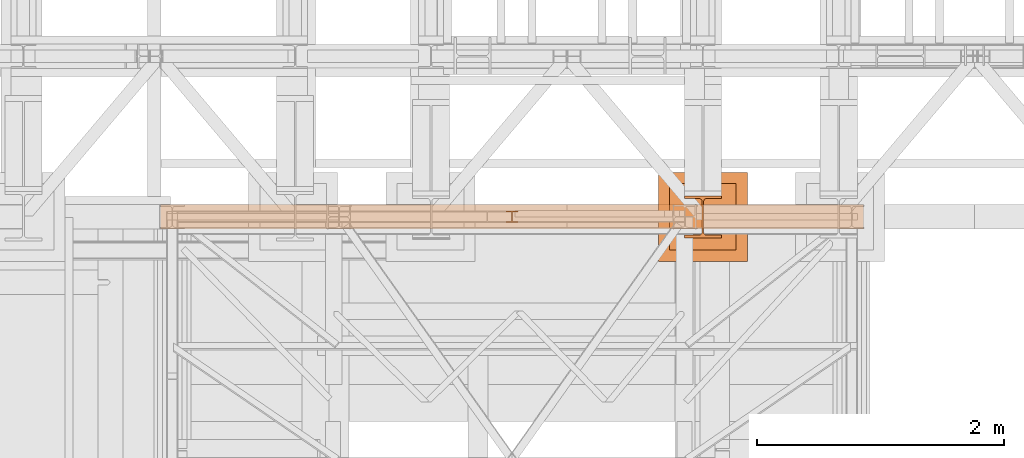
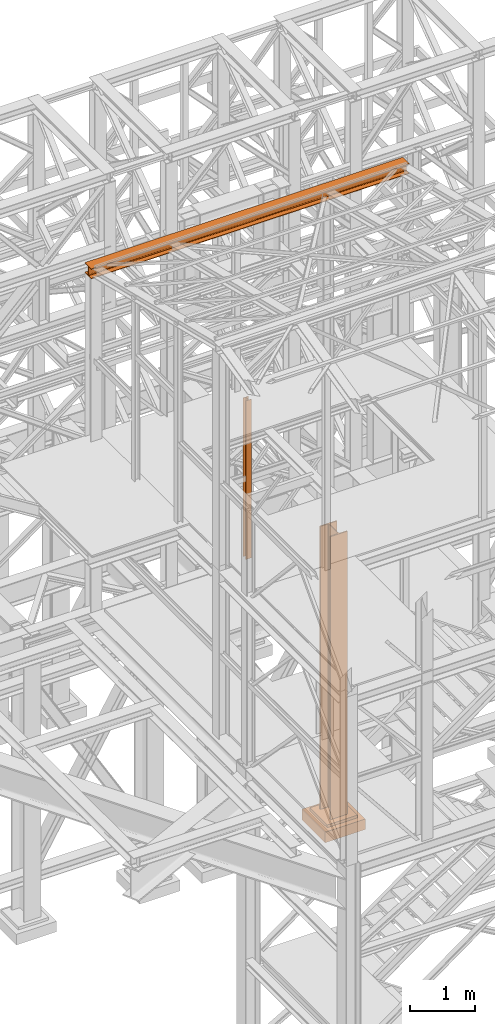
# One storey, part 74 of 208: 4 proxies.
"""IFC2X3 building model written with IfcOpenShell, lengths in millimetres."""

import ifcopenshell
import ifcopenshell.guid

model = None  # the IFC model being written
_history = None  # IfcOwnerHistory: only IFC2X3 demands one
_inside = {}  # id of a spatial element -> (the spatial element, [elements in it])
_under = {}  # id of a project, library or spatial element -> (it, [spatial elements below it])
_declared = {}  # id of a project -> (the project, [libraries it declares])
_typed = {}  # id of a type object -> (the type object, [elements of that type])
_made_of = {}  # id of a material, layer set ... -> (it, [elements and type objects made of it])


def new_model(schema):
    """Start an empty IFC model of exactly this schema.

    Asked for "IFC4X3", IfcOpenShell would pick the latest addendum, in which some entities
    have other attributes; the version numbers below select the first issue.
    IFC2X3 requires an IfcOwnerHistory on every rooted entity: one is made here for all.
    """
    global model, _history
    if schema == "IFC4X3":
        model = ifcopenshell.file(schema_version=(4, 3, 0, 0))
    else:
        model = ifcopenshell.file(schema=schema)
    _inside.clear()
    _under.clear()
    _declared.clear()
    _typed.clear()
    _made_of.clear()
    _history = None
    if model.schema == "IFC2X3":
        org = make("IfcOrganization", Name="unknown")
        user = make(
            "IfcPersonAndOrganization",
            ThePerson=make("IfcPerson", FamilyName="unknown"),
            TheOrganization=org,
        )
        app = make(
            "IfcApplication",
            ApplicationDeveloper=org,
            Version="unknown",
            ApplicationFullName="unknown",
            ApplicationIdentifier="unknown",
        )
        _history = make(
            "IfcOwnerHistory",
            OwningUser=user,
            OwningApplication=app,
            ChangeAction="ADDED",
            CreationDate=0,
        )
    return model


def make(cls, **values):
    """One entity of the class cls with the attributes given. An attribute that is None is left unset."""
    return model.create_entity(
        cls, **{name: value for name, value in values.items() if value is not None}
    )


def entity(cls, *values):
    """Any entity or typed value of the class cls, its attributes in the order of the schema. None: left unset."""
    e = model.create_entity(cls)
    for i, value in enumerate(values):
        if value is not None:
            e[i] = value
    return e


def rooted(cls, **values):
    """An entity with a GlobalId (a new one), such as an element, a storey or a relation."""
    return make(cls, GlobalId=ifcopenshell.guid.new(), OwnerHistory=_history, **values)


def si_unit(unit_type, name, prefix=None):
    """IfcSIUnit, for example si_unit("LENGTHUNIT", "METRE", prefix="MILLI")."""
    return make("IfcSIUnit", UnitType=unit_type, Prefix=prefix, Name=name)


def converted_unit(unit_type, name, factor, base, dimensions=None, offset=None):
    """IfcConversionBasedUnit, such as the inch: factor (a typed value) times the base unit."""
    return make(
        "IfcConversionBasedUnit"
        if offset is None
        else "IfcConversionBasedUnitWithOffset",
        ConversionOffset=offset,
        Dimensions=None
        if dimensions is None
        else entity("IfcDimensionalExponents", *dimensions),
        UnitType=unit_type,
        Name=name,
        ConversionFactor=make(
            "IfcMeasureWithUnit", ValueComponent=factor, UnitComponent=base
        ),
    )


def assignment(units):
    """IfcUnitAssignment: the units of a project."""
    return None if units is None else make("IfcUnitAssignment", Units=units)


def point(xyz):
    """IfcCartesianPoint."""
    return None if xyz is None else make("IfcCartesianPoint", Coordinates=xyz)


def direction(xyz):
    """IfcDirection."""
    return None if xyz is None else make("IfcDirection", DirectionRatios=xyz)


def frame(location, z_axis=None, x_axis=None):
    """IfcAxis2Placement3D, a coordinate frame: its origin and axes. An axis left out is left unset."""
    return make(
        "IfcAxis2Placement3D",
        Location=point(location),
        Axis=direction(z_axis),
        RefDirection=direction(x_axis),
    )


def origin():
    """The frame at (0, 0, 0) with its axes left unset."""
    return frame((0.0, 0.0, 0.0))


def origin_with_axes():
    """The frame at (0, 0, 0) with the z axis (0, 0, 1) and the x axis (1, 0, 0) written out."""
    return frame((0.0, 0.0, 0.0), z_axis=(0.0, 0.0, 1.0), x_axis=(1.0, 0.0, 0.0))


def place(relative_to, where):
    """IfcLocalPlacement: puts the frame where relative to a parent placement (None: the world)."""
    return make(
        "IfcLocalPlacement", PlacementRelTo=relative_to, RelativePlacement=where
    )


def context(
    kind, dimensions, precision=None, world=None, true_north=None, identifier=None
):
    """IfcGeometricRepresentationContext, for example the 3D "Model" context."""
    return make(
        "IfcGeometricRepresentationContext",
        ContextIdentifier=identifier,
        ContextType=kind,
        CoordinateSpaceDimension=dimensions,
        Precision=precision,
        WorldCoordinateSystem=world,
        TrueNorth=true_north,
    )


def subcontext(parent, identifier, kind, view, scale=None):
    """IfcGeometricRepresentationSubContext, for example "Body" below "Model"."""
    return make(
        "IfcGeometricRepresentationSubContext",
        ContextIdentifier=identifier,
        ContextType=kind,
        ParentContext=parent,
        TargetScale=scale,
        TargetView=view,
    )


def project(units=None, contexts=None):
    """IfcProject with its units and contexts."""
    return rooted(
        "IfcProject",
        Name="project",
        RepresentationContexts=contexts,
        UnitsInContext=assignment(units),
    )


def spatial(cls, under=None, at=None, **own):
    """A site, building, storey or space (cls), placed at a placement, below another one or the project."""
    s = rooted(cls, ObjectPlacement=at, **own)
    if under is not None:
        _under.setdefault(under.id(), (under, []))[1].append(s)
    return s


def faces_of(points, faces, orient=None, outer=None):
    """IfcFace entities. A face is a list of loops; a loop is a list of indices into points, from 0.

    orient and outer hold one flag for each loop. By default every Orientation is true, the
    first loop of a face is its IfcFaceOuterBound and the others are IfcFaceBound.
    """
    made = []
    for i, loops in enumerate(faces):
        bounds = []
        for j, loop in enumerate(loops):
            is_outer = j == 0 if outer is None else outer[i][j]
            bounds.append(
                make(
                    "IfcFaceOuterBound" if is_outer else "IfcFaceBound",
                    Bound=make("IfcPolyLoop", Polygon=[points[k] for k in loop]),
                    Orientation=True if orient is None else orient[i][j],
                )
            )
        made.append(make("IfcFace", Bounds=bounds))
    return made


def faceted_brep(points, faces, orient=None, outer=None, voids=None):
    """IfcFacetedBrep: a solid bounded by flat faces; with voids (closed shells), ...WithVoids."""
    shared = [point(p) for p in points]
    hull = make("IfcClosedShell", CfsFaces=faces_of(shared, faces, orient, outer))
    if voids is None:
        return make("IfcFacetedBrep", Outer=hull)
    return make(
        "IfcFacetedBrepWithVoids",
        Outer=hull,
        Voids=[
            make(cls, CfsFaces=faces_of(shared, fs, o, b)) for cls, fs, o, b in voids
        ],
    )


def shape(context_of_items, identifier, shape_type, items):
    """IfcShapeRepresentation: the items that make up one representation, for example the "Body"."""
    return make(
        "IfcShapeRepresentation",
        ContextOfItems=context_of_items,
        RepresentationIdentifier=identifier,
        RepresentationType=shape_type,
        Items=items,
    )


def material(Name=None, Category=None):
    """IfcMaterial."""
    return make("IfcMaterial", Name=Name, Category=Category)


def made_of(thing, what):
    """Note that an element or type object is made of a material, layer set ...; save() writes the relation."""
    if what is not None:
        _made_of.setdefault(what.id(), (what, []))[1].append(thing)
    return thing


def element(
    cls,
    number,
    at=None,
    inside=None,
    cuts=None,
    type_object=None,
    material=None,
    context=None,
    identifier="Body",
    shape_type=None,
    held_by="IfcProductDefinitionShape",
    body=None,
    shapes=None,
    **own,
):
    """One element of the class cls, such as IfcWall. Its Tag is "e" and its number.

    at: its placement. inside: the storey or other place that contains it. cuts: it is an
    opening in that element (IfcRelVoidsElement). A single representation is given by context,
    identifier, shape_type and body (its items); several are given by shapes. held_by: the class
    of the entity that holds the representations. save() writes the other relations.
    """
    e = rooted(cls, Tag="e%d" % number, ObjectPlacement=at, **own)
    if body is not None:
        shapes = [shape(context, identifier, shape_type, body)]
    if shapes is not None:
        e.Representation = make(held_by, Representations=shapes)
    if inside is not None:
        _inside.setdefault(inside.id(), (inside, []))[1].append(e)
    if cuts is not None:
        rooted(
            "IfcRelVoidsElement", RelatingBuildingElement=cuts, RelatedOpeningElement=e
        )
    if type_object is not None:
        _typed.setdefault(type_object.id(), (type_object, []))[1].append(e)
    return made_of(e, material)


def aggregate(whole, parts):
    """IfcRelAggregates: a whole, such as a stair, and the parts it consists of."""
    return rooted("IfcRelAggregates", RelatingObject=whole, RelatedObjects=parts)


def save(model, path):
    """Write the relations noted so far, then the file.

    IfcRelAggregates (storeys below a building ...), IfcRelContainedInSpatialStructure (elements
    in a storey), IfcRelDefinesByType, IfcRelAssociatesMaterial and IfcRelDeclares: one each for
    every whole, place, type object, material and project.
    """
    for whole, parts in _under.values():
        aggregate(whole, parts)
    for where, things in _inside.values():
        rooted(
            "IfcRelContainedInSpatialStructure",
            RelatedElements=things,
            RelatingStructure=where,
        )
    for kind, things in _typed.values():
        rooted("IfcRelDefinesByType", RelatedObjects=things, RelatingType=kind)
    for what, things in _made_of.values():
        rooted("IfcRelAssociatesMaterial", RelatedObjects=things, RelatingMaterial=what)
    for by, libraries in _declared.values():
        rooted("IfcRelDeclares", RelatingContext=by, RelatedDefinitions=libraries)
    model.write(path)


model = new_model("IFC2X3")

# Units and contexts
model_context = context("Model", 3, precision=1e-05, world=origin())
plan_context = context("Plan", 3, precision=1e-05, world=origin())
body_context = subcontext(model_context, "Body", "Model", "MODEL_VIEW")
ifc_project = project(units=[si_unit("LENGTHUNIT", "METRE", prefix="MILLI"), converted_unit("PLANEANGLEUNIT", "DEGREE", entity("IfcPlaneAngleMeasure", 0.0174532925199433), si_unit("PLANEANGLEUNIT", "RADIAN"), dimensions=[0, 0, 0, 0, 0, 0, 0]), si_unit("AREAUNIT", "SQUARE_METRE"), si_unit("VOLUMEUNIT", "CUBIC_METRE")], contexts=[model_context, plan_context])

# Building, storey
building_placement = place(None, origin())
building = spatial("IfcBuilding", under=ifc_project, at=building_placement, CompositionType="COMPLEX")
storey_placement = place(building_placement, origin_with_axes())
storey = spatial("IfcBuildingStorey", under=building, at=storey_placement, Name="Geschoss", CompositionType="ELEMENT")

# Proxies
proxy_1_placement = place(storey_placement, frame((1103.254962270171, -17362.57439031789, 11599.98999433756), z_axis=(0.0, 0.0, 1.0), x_axis=(1.0, 0.0, 0.0)))
element("IfcBuildingElementProxy", 1, at=proxy_1_placement, inside=storey, context=body_context, shape_type="Brep", body=[
    faceted_brep([(0.01000000000021828, 0.00999999999839929, 190.0100000000002), (5690.010012516976, 0.00999999999839929, 190.0100000000002), (5690.010012516976, 0.00999999999839929, 180.0100000000002), (0.01000000000021828, 0.00999999999839929, 180.0100000000002), (0.01000000000021828, 0.00999999999839929, 180.0100000000002), (5690.010012516976, 0.00999999999839929, 180.0100000000002), (5690.010012516976, 78.7599999999984, 180.0100000000002), (0.01000000000021828, 78.7599999999984, 180.0100000000002), (0.01000000000021828, 78.7599999999984, 180.0100000000002), (5690.010012516976, 78.7599999999984, 180.0100000000002), (5690.010012516976, 84.32228703057262, 179.128955961507), (0.01000000000021828, 84.32228703057262, 179.128955961507), (0.01000000000021828, 84.32228703057262, 179.128955961507), (5690.010012516976, 84.32228703057262, 179.128955961507), (5690.010012516976, 89.34011671053304, 176.5722836422683), (0.01000000000021828, 89.34011671053668, 176.5722836422683), (0.01000000000021828, 89.34011671053668, 176.5722836422683), (5690.010012516976, 89.34011671053304, 176.5722836422683), (5690.010012516976, 93.32228364226467, 172.5901167105349), (0.01000000000021828, 93.32228364226467, 172.5901167105349), (0.01000000000021828, 93.32228364226467, 172.5901167105349), (5690.010012516976, 93.32228364226467, 172.5901167105349), (5690.010012516976, 95.87895596150338, 167.5722870305744), (0.01000000000021828, 95.87895596150338, 167.5722870305744), (0.01000000000021828, 95.87895596150338, 167.5722870305744), (5690.010012516976, 95.87895596150338, 167.5722870305744), (5690.010012516976, 96.7599999999984, 162.0100000000002), (0.01000000000021828, 96.7599999999984, 162.0100000000002), (0.01000000000021828, 96.7599999999984, 162.0100000000002), (5690.010012516976, 96.7599999999984, 162.0100000000002), (5690.010012516976, 96.7599999999984, 28.01000000000022), (0.01000000000021828, 96.7599999999984, 28.01000000000022), (0.01000000000021828, 96.7599999999984, 28.01000000000022), (5690.010012516976, 96.7599999999984, 28.01000000000022), (5690.010012516976, 95.87895596150338, 22.44771296942599), (0.01000000000021828, 95.87895596150338, 22.44771296942599), (0.01000000000021828, 95.87895596150338, 22.44771296942599), (5690.010012516976, 95.87895596150338, 22.44771296942599), (5690.010012516976, 93.32228364226467, 17.42988328946558), (0.01000000000021828, 93.32228364226467, 17.42988328946558), (0.01000000000021828, 93.32228364226467, 17.42988328946558), (5690.010012516976, 93.32228364226467, 17.42988328946558), (5690.010012516976, 89.34011671053304, 13.44771635773213), (0.01000000000021828, 89.34011671053668, 13.44771635773395), (0.01000000000021828, 89.34011671053668, 13.44771635773395), (5690.010012516976, 89.34011671053304, 13.44771635773213), (5690.010012516976, 84.32228703057262, 10.89104403849342), (0.01000000000021828, 84.32228703057262, 10.89104403849342), (0.01000000000021828, 84.32228703057262, 10.89104403849342), (5690.010012516976, 84.32228703057262, 10.89104403849342), (5690.010012516976, 80.0099999999984, 10.01000000000022), (0.01000000000021828, 80.0099999999984, 10.01000000000022), (0.01000000000021828, 80.0099999999984, 10.01000000000022), (5690.010012516976, 80.0099999999984, 10.01000000000022), (5690.010012516976, 0.00999999999839929, 10.01000000000022), (0.01000000000021828, 0.00999999999839929, 10.01000000000022), (0.01000000000021828, 0.00999999999839929, 10.01000000000022), (5690.010012516976, 0.00999999999839929, 10.01000000000022), (5690.010012516976, 0.00999999999839929, 0.01000000000021828), (0.01000000000021828, 0.00999999999839929, 0.01000000000021828), (0.01000000000021828, 0.00999999999839929, 0.01000000000021828), (5690.010012516976, 0.00999999999839929, 0.01000000000021828), (5690.010012516976, 200.0099999999984, 0.01000000000021828), (0.01000000000021828, 200.0099999999984, 0.01000000000021828), (0.01000000000021828, 200.0099999999984, 0.01000000000021828), (5690.010012516976, 200.0099999999984, 0.01000000000021828), (5690.010012516976, 200.0099999999984, 10.01000000000022), (0.01000000000021828, 200.0099999999984, 10.01000000000022), (0.01000000000021828, 200.0099999999984, 10.01000000000022), (5690.010012516976, 200.0099999999984, 10.01000000000022), (5690.010012516976, 121.2599999999984, 10.01000000000022), (0.01000000000021828, 121.2599999999984, 10.01000000000022), (0.01000000000021828, 121.2599999999984, 10.01000000000022), (5690.010012516976, 121.2599999999984, 10.01000000000022), (5690.010012516976, 115.6977129694242, 10.89104403849342), (0.01000000000021828, 115.6977129694242, 10.89104403849342), (0.01000000000021828, 115.6977129694242, 10.89104403849342), (5690.010012516976, 115.6977129694242, 10.89104403849342), (5690.010012516976, 110.6798832894638, 13.44771635773213), (0.01000000000021828, 110.6798832894638, 13.44771635773213), (0.01000000000021828, 110.6798832894638, 13.44771635773213), (5690.010012516976, 110.6798832894638, 13.44771635773213), (5690.010012516976, 106.6977163577285, 17.42988328946558), (0.01000000000021828, 106.6977163577285, 17.42988328946558), (0.01000000000021828, 106.6977163577285, 17.42988328946558), (5690.010012516976, 106.6977163577285, 17.42988328946558), (5690.010012516976, 104.1410440384934, 22.44771296942599), (0.01000000000021828, 104.1410440384934, 22.44771296942599), (0.01000000000021828, 104.1410440384934, 22.44771296942599), (5690.010012516976, 104.1410440384934, 22.44771296942599), (5690.010012516976, 103.2599999999984, 28.01000000000022), (0.01000000000021828, 103.2599999999984, 28.01000000000022), (0.01000000000021828, 103.2599999999984, 28.01000000000022), (5690.010012516976, 103.2599999999984, 28.01000000000022), (5690.010012516976, 103.2599999999984, 162.0100000000002), (0.01000000000021828, 103.2599999999984, 162.0100000000002), (0.01000000000021828, 103.2599999999984, 162.0100000000002), (5690.010012516976, 103.2599999999984, 162.0100000000002), (5690.010012516976, 104.1410440384934, 167.5722870305744), (0.01000000000021828, 104.1410440384934, 167.5722870305744), (0.01000000000021828, 104.1410440384934, 167.5722870305744), (5690.010012516976, 104.1410440384934, 167.5722870305744), (5690.010012516976, 106.6977163577285, 172.5901167105349), (0.01000000000021828, 106.6977163577285, 172.5901167105349), (0.01000000000021828, 106.6977163577285, 172.5901167105349), (5690.010012516976, 106.6977163577285, 172.5901167105349), (5690.010012516976, 110.6798832894638, 176.5722836422683), (0.01000000000021828, 110.6798832894638, 176.5722836422683), (0.01000000000021828, 110.6798832894638, 176.5722836422683), (5690.010012516976, 110.6798832894638, 176.5722836422683), (5690.010012516976, 115.6977129694242, 179.128955961507), (0.01000000000021828, 115.6977129694242, 179.128955961507), (0.01000000000021828, 115.6977129694242, 179.128955961507), (5690.010012516976, 115.6977129694242, 179.128955961507), (5690.010012516976, 121.2599999999984, 180.0100000000002), (0.01000000000021828, 121.2599999999984, 180.0100000000002), (0.01000000000021828, 121.2599999999984, 180.0100000000002), (5690.010012516976, 121.2599999999984, 180.0100000000002), (5690.010012516976, 200.0099999999984, 180.0100000000002), (0.01000000000021828, 200.0099999999984, 180.0100000000002), (0.01000000000021828, 200.0099999999984, 180.0100000000002), (5690.010012516976, 200.0099999999984, 180.0100000000002), (5690.010012516976, 200.0099999999984, 190.0100000000002), (0.01000000000021828, 200.0099999999984, 190.0100000000002), (0.01000000000021828, 200.0099999999984, 190.0100000000002), (5690.010012516976, 200.0099999999984, 190.0100000000002), (5690.010012516976, 0.00999999999839929, 190.0100000000002), (0.01000000000021828, 0.00999999999839929, 190.0100000000002), (5690.010012516976, 0.00999999999839929, 190.0100000000002), (5690.010012516976, 200.0099999999984, 190.0100000000002), (5690.010012516976, 200.0099999999984, 180.0100000000002), (5690.010012516976, 121.2599999999984, 180.0100000000002), (5690.010012516976, 115.6977129694242, 179.128955961507), (5690.010012516976, 110.6798832894638, 176.5722836422683), (5690.010012516976, 106.6977163577285, 172.5901167105349), (5690.010012516976, 104.1410440384934, 167.5722870305744), (5690.010012516976, 103.2599999999984, 162.0100000000002), (5690.010012516976, 103.2599999999984, 28.01000000000022), (5690.010012516976, 104.1410440384934, 22.44771296942599), (5690.010012516976, 106.6977163577285, 17.42988328946558), (5690.010012516976, 110.6798832894638, 13.44771635773213), (5690.010012516976, 115.6977129694242, 10.89104403849342), (5690.010012516976, 121.2599999999984, 10.01000000000022), (5690.010012516976, 200.0099999999984, 10.01000000000022), (5690.010012516976, 200.0099999999984, 0.01000000000021828), (5690.010012516976, 0.00999999999839929, 0.01000000000021828), (5690.010012516976, 0.00999999999839929, 10.01000000000022), (5690.010012516976, 80.0099999999984, 10.01000000000022), (5690.010012516976, 84.32228703057262, 10.89104403849342), (5690.010012516976, 89.34011671053304, 13.44771635773213), (5690.010012516976, 93.32228364226467, 17.42988328946558), (5690.010012516976, 95.87895596150338, 22.44771296942599), (5690.010012516976, 96.7599999999984, 28.01000000000022), (5690.010012516976, 96.7599999999984, 162.0100000000002), (5690.010012516976, 95.87895596150338, 167.5722870305744), (5690.010012516976, 93.32228364226467, 172.5901167105349), (5690.010012516976, 89.34011671053304, 176.5722836422683), (5690.010012516976, 84.32228703057262, 179.128955961507), (5690.010012516976, 78.7599999999984, 180.0100000000002), (5690.010012516976, 0.00999999999839929, 180.0100000000002), (0.01000000000021828, 0.00999999999839929, 180.0100000000002), (0.01000000000021828, 78.7599999999984, 180.0100000000002), (0.01000000000021828, 84.32228703057262, 179.128955961507), (0.01000000000021828, 89.34011671053668, 176.5722836422683), (0.01000000000021828, 93.32228364226467, 172.5901167105349), (0.01000000000021828, 95.87895596150338, 167.5722870305744), (0.01000000000021828, 96.7599999999984, 162.0100000000002), (0.01000000000021828, 96.7599999999984, 28.01000000000022), (0.01000000000021828, 95.87895596150338, 22.44771296942599), (0.01000000000021828, 93.32228364226467, 17.42988328946558), (0.01000000000021828, 89.34011671053668, 13.44771635773395), (0.01000000000021828, 84.32228703057262, 10.89104403849342), (0.01000000000021828, 80.0099999999984, 10.01000000000022), (0.01000000000021828, 0.00999999999839929, 10.01000000000022), (0.01000000000021828, 0.00999999999839929, 0.01000000000021828), (0.01000000000021828, 200.0099999999984, 0.01000000000021828), (0.01000000000021828, 200.0099999999984, 10.01000000000022), (0.01000000000021828, 121.2599999999984, 10.01000000000022), (0.01000000000021828, 115.6977129694242, 10.89104403849342), (0.01000000000021828, 110.6798832894638, 13.44771635773213), (0.01000000000021828, 106.6977163577285, 17.42988328946558), (0.01000000000021828, 104.1410440384934, 22.44771296942599), (0.01000000000021828, 103.2599999999984, 28.01000000000022), (0.01000000000021828, 103.2599999999984, 162.0100000000002), (0.01000000000021828, 104.1410440384934, 167.5722870305744), (0.01000000000021828, 106.6977163577285, 172.5901167105349), (0.01000000000021828, 110.6798832894638, 176.5722836422683), (0.01000000000021828, 115.6977129694242, 179.128955961507), (0.01000000000021828, 121.2599999999984, 180.0100000000002), (0.01000000000021828, 200.0099999999984, 180.0100000000002), (0.01000000000021828, 200.0099999999984, 190.0100000000002), (0.01000000000021828, 0.00999999999839929, 190.0100000000002)], [[[0, 1, 2, 3]], [[4, 5, 6, 7]], [[8, 9, 10, 11]], [[12, 13, 14, 15]], [[16, 17, 18, 19]], [[20, 21, 22, 23]], [[24, 25, 26, 27]], [[28, 29, 30, 31]], [[32, 33, 34, 35]], [[36, 37, 38, 39]], [[40, 41, 42, 43]], [[44, 45, 46, 47]], [[48, 49, 50, 51]], [[52, 53, 54, 55]], [[56, 57, 58, 59]], [[60, 61, 62, 63]], [[64, 65, 66, 67]], [[68, 69, 70, 71]], [[72, 73, 74, 75]], [[76, 77, 78, 79]], [[80, 81, 82, 83]], [[84, 85, 86, 87]], [[88, 89, 90, 91]], [[92, 93, 94, 95]], [[96, 97, 98, 99]], [[100, 101, 102, 103]], [[104, 105, 106, 107]], [[108, 109, 110, 111]], [[112, 113, 114, 115]], [[116, 117, 118, 119]], [[120, 121, 122, 123]], [[124, 125, 126, 127]], [[128, 129, 130, 131, 132, 133, 134, 135, 136, 137, 138, 139, 140, 141, 142, 143, 144, 145, 146, 147, 148, 149, 150, 151, 152, 153, 154, 155, 156, 157, 158, 159]], [[160, 161, 162, 163, 164, 165, 166, 167, 168, 169, 170, 171, 172, 173, 174, 175, 176, 177, 178, 179, 180, 181, 182, 183, 184, 185, 186, 187, 188, 189, 190, 191]]], orient=[[False], [False], [False], [False], [False], [False], [False], [False], [False], [False], [False], [False], [False], [False], [False], [False], [False], [False], [False], [False], [False], [False], [False], [False], [False], [False], [False], [False], [False], [False], [False], [False], [False], [False]]),
])
proxy_2_placement = place(storey_placement, frame((3898.254968528661, -17310.57439031789, 5284.990005364416), z_axis=(0.0, 0.0, 1.0), x_axis=(1.0, 0.0, 0.0)))
element("IfcBuildingElementProxy", 2, at=proxy_2_placement, inside=storey, context=body_context, shape_type="Brep", body=[
    faceted_brep([(100.010000000002, 88.0099999999984, 0.01000000000021828), (100.010000000002, 96.0099999999984, 0.01000000000021828), (0.01000000000203727, 96.0099999999984, 0.01000000000021828), (0.01000000000203727, 88.0099999999984, 0.01000000000021828), (47.51000000000204, 88.0099999999984, 0.01000000000021828), (47.51000000000204, 8.0099999999984, 0.01000000000021828), (0.01000000000203727, 8.0099999999984, 0.01000000000021828), (0.01000000000203727, 0.00999999999839929, 0.01000000000021828), (100.010000000002, 0.00999999999839929, 0.01000000000021828), (100.010000000002, 8.0099999999984, 0.01000000000021828), (52.51000000000204, 8.0099999999984, 0.01000000000021828), (52.51000000000204, 88.0099999999984, 0.01000000000021828), (100.010000000002, 96.0099999999984, 0.01000000000021828), (100.010000000002, 88.0099999999984, 0.01000000000021828), (100.0100000000002, 88.0099999999984, 3000.009996721741), (100.0100000000002, 96.0099999999984, 3000.009996721741), (0.01000000000203727, 96.0099999999984, 0.01000000000021828), (100.010000000002, 96.0099999999984, 0.01000000000021828), (100.0100000000002, 96.0099999999984, 3000.009996721741), (0.01000000000021828, 96.0099999999984, 3000.009996721741), (0.01000000000203727, 88.0099999999984, 0.01000000000021828), (0.01000000000203727, 96.0099999999984, 0.01000000000021828), (0.01000000000021828, 96.0099999999984, 3000.009996721741), (0.01000000000021828, 88.0099999999984, 3000.009996721741), (47.51000000000204, 88.0099999999984, 0.01000000000021828), (0.01000000000203727, 88.0099999999984, 0.01000000000021828), (0.01000000000021828, 88.0099999999984, 3000.009996721741), (47.51000000000022, 88.0099999999984, 3000.009996721741), (47.51000000000204, 8.0099999999984, 0.01000000000021828), (47.51000000000204, 88.0099999999984, 0.01000000000021828), (47.51000000000022, 88.0099999999984, 3000.009996721741), (47.51000000000022, 8.0099999999984, 3000.009996721741), (0.01000000000203727, 8.0099999999984, 0.01000000000021828), (47.51000000000204, 8.0099999999984, 0.01000000000021828), (47.51000000000022, 8.0099999999984, 3000.009996721741), (0.01000000000021828, 8.0099999999984, 3000.009996721741), (0.01000000000203727, 0.00999999999839929, 0.01000000000021828), (0.01000000000203727, 8.0099999999984, 0.01000000000021828), (0.01000000000021828, 8.0099999999984, 3000.009996721741), (0.01000000000021828, 0.00999999999839929, 3000.009996721741), (100.010000000002, 0.00999999999839929, 0.01000000000021828), (0.01000000000203727, 0.00999999999839929, 0.01000000000021828), (0.01000000000021828, 0.00999999999839929, 3000.009996721741), (100.0100000000002, 0.00999999999839929, 3000.009996721741), (100.010000000002, 8.0099999999984, 0.01000000000021828), (100.010000000002, 0.00999999999839929, 0.01000000000021828), (100.0100000000002, 0.00999999999839929, 3000.009996721741), (100.0100000000002, 8.0099999999984, 3000.009996721741), (52.51000000000204, 8.0099999999984, 0.01000000000021828), (100.010000000002, 8.0099999999984, 0.01000000000021828), (100.0100000000002, 8.0099999999984, 3000.009996721741), (52.51000000000022, 8.0099999999984, 3000.009996721741), (52.51000000000204, 88.0099999999984, 0.01000000000021828), (52.51000000000204, 8.0099999999984, 0.01000000000021828), (52.51000000000022, 8.0099999999984, 3000.009996721741), (52.51000000000022, 88.0099999999984, 3000.009996721741), (100.010000000002, 88.0099999999984, 0.01000000000021828), (52.51000000000204, 88.0099999999984, 0.01000000000021828), (52.51000000000022, 88.0099999999984, 3000.009996721741), (100.0100000000002, 88.0099999999984, 3000.009996721741), (100.0100000000002, 88.0099999999984, 3000.009996721741), (52.51000000000022, 88.0099999999984, 3000.009996721741), (52.51000000000022, 8.0099999999984, 3000.009996721741), (100.0100000000002, 8.0099999999984, 3000.009996721741), (100.0100000000002, 0.00999999999839929, 3000.009996721741), (0.01000000000021828, 0.00999999999839929, 3000.009996721741), (0.01000000000021828, 8.0099999999984, 3000.009996721741), (47.51000000000022, 8.0099999999984, 3000.009996721741), (47.51000000000022, 88.0099999999984, 3000.009996721741), (0.01000000000021828, 88.0099999999984, 3000.009996721741), (0.01000000000021828, 96.0099999999984, 3000.009996721741), (100.0100000000002, 96.0099999999984, 3000.009996721741)], [[[0, 1, 2, 3, 4, 5, 6, 7, 8, 9, 10, 11]], [[12, 13, 14, 15]], [[16, 17, 18, 19]], [[20, 21, 22, 23]], [[24, 25, 26, 27]], [[28, 29, 30, 31]], [[32, 33, 34, 35]], [[36, 37, 38, 39]], [[40, 41, 42, 43]], [[44, 45, 46, 47]], [[48, 49, 50, 51]], [[52, 53, 54, 55]], [[56, 57, 58, 59]], [[60, 61, 62, 63, 64, 65, 66, 67, 68, 69, 70, 71]]], orient=[[False], [False], [False], [False], [False], [False], [False], [False], [False], [False], [False], [False], [False], [False]]),
])
ifc_material = material(Name="35/80cm")
proxy_3_placement = place(storey_placement, frame((5343.254962568202, -17432.57439531565, -65.01000000000022), z_axis=(0.0, 0.0, 1.0), x_axis=(1.0, 0.0, 0.0)))
element("IfcBuildingElementProxy", 3, at=proxy_3_placement, inside=storey, material=ifc_material, context=body_context, shape_type="Brep", body=[
    faceted_brep([(300.0100119209292, 0.00999999999839929, 0.01000000000027512), (300.0100119209292, 21.51000631809075, 0.01000000000027512), (183.0100057816508, 21.51000631809075, 0.01000000000027512), (169.036290997863, 24.30682016372521, 0.01000000000027512), (158.8068282401564, 34.5362885093673, 0.01000000000027512), (156.0100060126188, 48.51000143050987, 0.01000000000027512), (156.0100060126188, 291.509994695185, 0.01000000000027512), (158.8068282401564, 305.4837150669082, 0.01000000000027512), (169.036290997863, 315.7131685113891, 0.01000000000027512), (183.0100057816508, 318.5099972581847, 0.01000000000027512), (300.0100119209292, 318.5099972581847, 0.01000000000027512), (300.0100119209292, 340.0100035762771, 0.01000000000027512), (0.01000000000021828, 340.0100035762771, 0.01000000000027512), (0.01000000000021828, 318.5099972581847, 0.01000000000027512), (117.0100061392786, 318.5099972581847, 0.01000000000027512), (130.9837209230664, 315.7131685113891, 0.01000000000027512), (141.213183680773, 305.4837150669082, 0.01000000000027512), (144.0100059083106, 291.509994695185, 0.01000000000027512), (144.0100059083106, 48.51000143050987, 0.01000000000027512), (141.213183680773, 34.5362885093673, 0.01000000000027512), (130.9837209230664, 24.30682016372521, 0.01000000000027512), (117.0100061392786, 21.51000631809075, 0.01000000000027512), (0.01000000000021828, 21.51000631809075, 0.01000000000027512), (0.01000000000021828, 0.00999999999839929, 0.01000000000027512), (300.0100119209292, 21.51000631809075, 5350.010005364416), (300.0100119209292, 0.00999999999839929, 5350.010005364416), (0.01000000000021828, 0.00999999999839929, 5350.010005364416), (0.01000000000021828, 21.51000631809075, 5350.010005364416), (117.0100061392786, 21.51000631809075, 5350.010005364416), (130.9837209230664, 24.30682016372521, 5350.010005364416), (141.213183680773, 34.5362885093673, 5350.010005364416), (144.0100059083106, 48.51000143050987, 5350.010005364416), (144.0100059083106, 291.509994695185, 5350.010005364416), (141.213183680773, 305.4837150669082, 5350.010005364416), (130.9837209230664, 315.7131685113891, 5350.010005364416), (117.0100061392786, 318.5099972581847, 5350.010005364416), (0.01000000000021828, 318.5099972581847, 5350.010005364416), (0.01000000000021828, 340.0100035762771, 5350.010005364416), (300.0100119209292, 340.0100035762771, 5350.010005364416), (300.0100119209292, 318.5099972581847, 5350.010005364416), (183.0100057816508, 318.5099972581847, 5350.010005364416), (169.036290997863, 315.7131685113891, 5350.010005364416), (158.8068282401564, 305.4837150669082, 5350.010005364416), (156.0100060126188, 291.509994695185, 5350.010005364416), (156.0100060126188, 48.51000143050987, 5350.010005364416), (158.8068282401564, 34.5362885093673, 5350.010005364416), (169.036290997863, 24.30682016372521, 5350.010005364416), (183.0100057816508, 21.51000631809075, 5350.010005364416), (300.0100119209292, 21.51000631809075, 0.01000000000027512), (300.0100119209292, 0.00999999999839929, 0.01000000000027512), (300.0100119209292, 0.00999999999839929, 5350.010005364416), (300.0100119209292, 21.51000631809075, 5350.010005364416), (183.0100057816508, 21.51000631809075, 0.01000000000027512), (300.0100119209292, 21.51000631809075, 0.01000000000027512), (300.0100119209292, 21.51000631809075, 5350.010005364416), (183.0100057816508, 21.51000631809075, 5350.010005364416), (169.036290997863, 24.30682016372521, 0.01000000000027512), (183.0100057816508, 21.51000631809075, 0.01000000000027512), (183.0100057816508, 21.51000631809075, 5350.010005364416), (169.036290997863, 24.30682016372521, 5350.010005364416), (158.8068282401564, 34.5362885093673, 0.01000000000027512), (169.036290997863, 24.30682016372521, 0.01000000000027512), (169.036290997863, 24.30682016372521, 5350.010005364416), (158.8068282401564, 34.5362885093673, 5350.010005364416), (156.0100060126188, 48.51000143050987, 0.01000000000027512), (158.8068282401564, 34.5362885093673, 0.01000000000027512), (158.8068282401564, 34.5362885093673, 5350.010005364416), (156.0100060126188, 48.51000143050987, 5350.010005364416), (156.0100060126188, 291.509994695185, 0.01000000000027512), (156.0100060126188, 48.51000143050987, 0.01000000000027512), (156.0100060126188, 48.51000143050987, 5350.010005364416), (156.0100060126188, 291.509994695185, 5350.010005364416), (158.8068282401564, 305.4837150669082, 0.01000000000027512), (156.0100060126188, 291.509994695185, 0.01000000000027512), (156.0100060126188, 291.509994695185, 5350.010005364416), (158.8068282401564, 305.4837150669082, 5350.010005364416), (169.036290997863, 315.7131685113891, 0.01000000000027512), (158.8068282401564, 305.4837150669082, 0.01000000000027512), (158.8068282401564, 305.4837150669082, 5350.010005364416), (169.036290997863, 315.7131685113891, 5350.010005364416), (183.0100057816508, 318.5099972581847, 0.01000000000027512), (169.036290997863, 315.7131685113891, 0.01000000000027512), (169.036290997863, 315.7131685113891, 5350.010005364416), (183.0100057816508, 318.5099972581847, 5350.010005364416), (300.0100119209292, 318.5099972581847, 0.01000000000027512), (183.0100057816508, 318.5099972581847, 0.01000000000027512), (183.0100057816508, 318.5099972581847, 5350.010005364416), (300.0100119209292, 318.5099972581847, 5350.010005364416), (300.0100119209292, 340.0100035762771, 0.01000000000027512), (300.0100119209292, 318.5099972581847, 0.01000000000027512), (300.0100119209292, 318.5099972581847, 5350.010005364416), (300.0100119209292, 340.0100035762771, 5350.010005364416), (0.01000000000021828, 340.0100035762771, 0.01000000000027512), (300.0100119209292, 340.0100035762771, 0.01000000000027512), (300.0100119209292, 340.0100035762771, 5350.010005364416), (0.01000000000021828, 340.0100035762771, 5350.010005364416), (0.01000000000021828, 318.5099972581847, 0.01000000000027512), (0.01000000000021828, 340.0100035762771, 0.01000000000027512), (0.01000000000021828, 340.0100035762771, 5350.010005364416), (0.01000000000021828, 318.5099972581847, 5350.010005364416), (117.0100061392786, 318.5099972581847, 0.01000000000027512), (0.01000000000021828, 318.5099972581847, 0.01000000000027512), (0.01000000000021828, 318.5099972581847, 5350.010005364416), (117.0100061392786, 318.5099972581847, 5350.010005364416), (130.9837209230664, 315.7131685113891, 0.01000000000027512), (117.0100061392786, 318.5099972581847, 0.01000000000027512), (117.0100061392786, 318.5099972581847, 5350.010005364416), (130.9837209230664, 315.7131685113891, 5350.010005364416), (141.213183680773, 305.4837150669082, 0.01000000000027512), (130.9837209230664, 315.7131685113891, 0.01000000000027512), (130.9837209230664, 315.7131685113891, 5350.010005364416), (141.213183680773, 305.4837150669082, 5350.010005364416), (144.0100059083106, 291.509994695185, 0.01000000000027512), (141.213183680773, 305.4837150669082, 0.01000000000027512), (141.213183680773, 305.4837150669082, 5350.010005364416), (144.0100059083106, 291.509994695185, 5350.010005364416), (144.0100059083106, 48.51000143050987, 0.01000000000027512), (144.0100059083106, 291.509994695185, 0.01000000000027512), (144.0100059083106, 291.509994695185, 5350.010005364416), (144.0100059083106, 48.51000143050987, 5350.010005364416), (141.213183680773, 34.5362885093673, 0.01000000000027512), (144.0100059083106, 48.51000143050987, 0.01000000000027512), (144.0100059083106, 48.51000143050987, 5350.010005364416), (141.213183680773, 34.5362885093673, 5350.010005364416), (130.9837209230664, 24.30682016372521, 0.01000000000027512), (141.213183680773, 34.5362885093673, 0.01000000000027512), (141.213183680773, 34.5362885093673, 5350.010005364416), (130.9837209230664, 24.30682016372521, 5350.010005364416), (117.0100061392786, 21.51000631809075, 0.01000000000027512), (130.9837209230664, 24.30682016372521, 0.01000000000027512), (130.9837209230664, 24.30682016372521, 5350.010005364416), (117.0100061392786, 21.51000631809075, 5350.010005364416), (0.01000000000021828, 21.51000631809075, 0.01000000000027512), (117.0100061392786, 21.51000631809075, 0.01000000000027512), (117.0100061392786, 21.51000631809075, 5350.010005364416), (0.01000000000021828, 21.51000631809075, 5350.010005364416), (0.01000000000021828, 0.00999999999839929, 0.01000000000027512), (0.01000000000021828, 21.51000631809075, 0.01000000000027512), (0.01000000000021828, 21.51000631809075, 5350.010005364416), (0.01000000000021828, 0.00999999999839929, 5350.010005364416), (300.0100119209292, 0.00999999999839929, 0.01000000000027512), (0.01000000000021828, 0.00999999999839929, 0.01000000000027512), (0.01000000000021828, 0.00999999999839929, 5350.010005364416), (300.0100119209292, 0.00999999999839929, 5350.010005364416)], [[[0, 1, 2, 3, 4, 5, 6, 7, 8, 9, 10, 11, 12, 13, 14, 15, 16, 17, 18, 19, 20, 21, 22, 23]], [[24, 25, 26, 27, 28, 29, 30, 31, 32, 33, 34, 35, 36, 37, 38, 39, 40, 41, 42, 43, 44, 45, 46, 47]], [[48, 49, 50, 51]], [[52, 53, 54, 55]], [[56, 57, 58, 59]], [[60, 61, 62, 63]], [[64, 65, 66, 67]], [[68, 69, 70, 71]], [[72, 73, 74, 75]], [[76, 77, 78, 79]], [[80, 81, 82, 83]], [[84, 85, 86, 87]], [[88, 89, 90, 91]], [[92, 93, 94, 95]], [[96, 97, 98, 99]], [[100, 101, 102, 103]], [[104, 105, 106, 107]], [[108, 109, 110, 111]], [[112, 113, 114, 115]], [[116, 117, 118, 119]], [[120, 121, 122, 123]], [[124, 125, 126, 127]], [[128, 129, 130, 131]], [[132, 133, 134, 135]], [[136, 137, 138, 139]], [[140, 141, 142, 143]]], orient=[[False], [False], [False], [False], [False], [False], [False], [False], [False], [False], [False], [False], [False], [False], [False], [False], [False], [False], [False], [False], [False], [False], [False], [False], [False], [False]]),
])
proxy_4_placement = place(storey_placement, frame((5133.254968528667, -17622.57439531565, -315.0099999999999), z_axis=(0.0, 0.0, 1.0), x_axis=(1.0, 0.0, 0.0)))
element("IfcBuildingElementProxy", 4, at=proxy_4_placement, inside=storey, context=body_context, shape_type="Brep", body=[
    faceted_brep([(630.0100000000002, 630.0099999999984, 250.01), (630.0100000000002, 90.0099999999984, 250.01), (90.01000000000022, 90.0099999999984, 250.01), (90.01000000000022, 630.0099999999984, 250.01), (630.0100000000002, 630.0099999999984, 200.01), (630.0100000000002, 90.0099999999984, 200.01), (630.0100000000002, 90.0099999999984, 250.01), (630.0100000000002, 630.0099999999984, 250.01), (90.01000000000022, 630.0099999999984, 200.01), (630.0100000000002, 630.0099999999984, 200.01), (630.0100000000002, 630.0099999999984, 250.01), (90.01000000000022, 630.0099999999984, 250.01), (90.01000000000022, 90.0099999999984, 200.01), (90.01000000000022, 630.0099999999984, 200.01), (90.01000000000022, 630.0099999999984, 250.01), (90.01000000000022, 90.0099999999984, 250.01), (630.0100000000002, 90.0099999999984, 200.01), (90.01000000000022, 90.0099999999984, 200.01), (90.01000000000022, 90.0099999999984, 250.01), (630.0100000000002, 90.0099999999984, 250.01), (720.0100000000002, 0.00999999999839929, 0.009999999999990905), (720.0100000000002, 720.0099999999984, 0.009999999999990905), (0.01000000000021828, 720.0099999999984, 0.009999999999990905), (0.01000000000021828, 0.00999999999839929, 0.009999999999990905), (720.0100000000002, 720.0099999999984, 200.01), (720.0100000000002, 0.00999999999839929, 200.01), (0.01000000000021828, 0.00999999999839929, 200.01), (0.01000000000021828, 720.0099999999984, 200.01), (90.01000000000022, 90.0099999999984, 200.01), (630.0100000000002, 90.0099999999984, 200.01), (630.0100000000002, 630.0099999999984, 200.01), (90.01000000000022, 630.0099999999984, 200.01), (720.0100000000002, 720.0099999999984, 0.009999999999990905), (720.0100000000002, 0.00999999999839929, 0.009999999999990905), (720.0100000000002, 0.00999999999839929, 200.01), (720.0100000000002, 720.0099999999984, 200.01), (0.01000000000021828, 720.0099999999984, 0.009999999999990905), (720.0100000000002, 720.0099999999984, 0.009999999999990905), (720.0100000000002, 720.0099999999984, 200.01), (0.01000000000021828, 720.0099999999984, 200.01), (0.01000000000021828, 0.00999999999839929, 0.009999999999990905), (0.01000000000021828, 720.0099999999984, 0.009999999999990905), (0.01000000000021828, 720.0099999999984, 200.01), (0.01000000000021828, 0.00999999999839929, 200.01), (720.0100000000002, 0.00999999999839929, 0.009999999999990905), (0.01000000000021828, 0.00999999999839929, 0.009999999999990905), (0.01000000000021828, 0.00999999999839929, 200.01), (720.0100000000002, 0.00999999999839929, 200.01)], [[[0, 1, 2, 3]], [[4, 5, 6, 7]], [[8, 9, 10, 11]], [[12, 13, 14, 15]], [[16, 17, 18, 19]], [[20, 21, 22, 23]], [[24, 25, 26, 27], [28, 29, 30, 31]], [[32, 33, 34, 35]], [[36, 37, 38, 39]], [[40, 41, 42, 43]], [[44, 45, 46, 47]]], orient=[[False], [False], [False], [False], [False], [False], [False, False], [False], [False], [False], [False]]),
])

save(model, "model.ifc")
